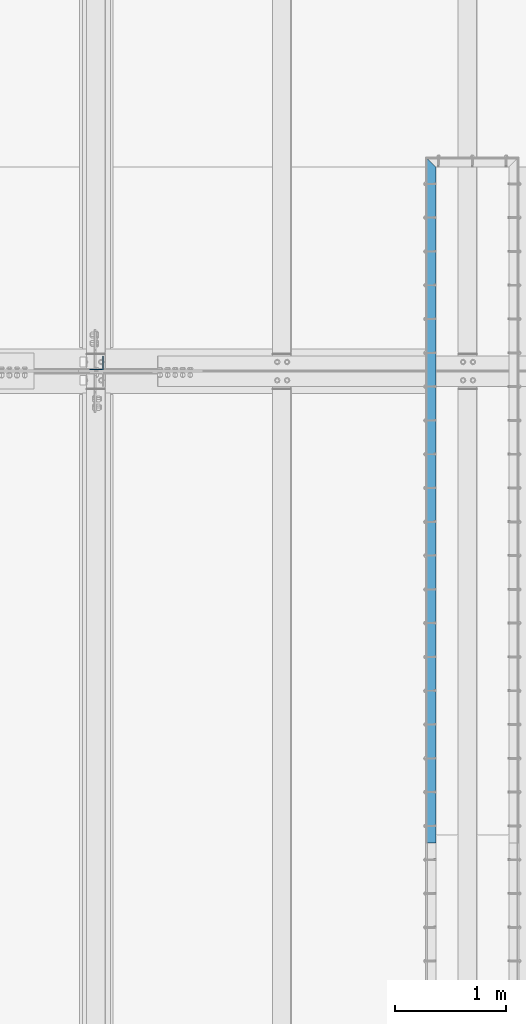
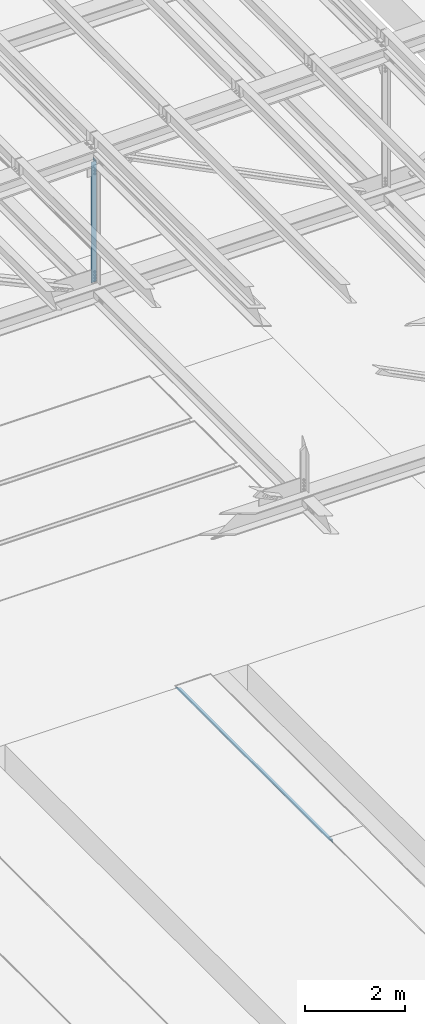
# One storey, part 1845 of 3843: 2 beams, 2 elements without a shape of their own.
"""IFC2X3 building model written with IfcOpenShell, lengths in millimetres."""

from ifc_helpers import new_model, si_unit, frame, origin_with_axes, place, context, subcontext, project, spatial, faceted_brep, material, type_object, element, aggregate, save


model = new_model("IFC2X3")

# Units and contexts
model_context = context("Model", 3, precision=1e-05, world=origin_with_axes())
body_context = subcontext(model_context, "Body", "Model", "MODEL_VIEW")
ifc_project = project(units=[si_unit("LENGTHUNIT", "METRE", prefix="MILLI"), si_unit("AREAUNIT", "SQUARE_METRE"), si_unit("VOLUMEUNIT", "CUBIC_METRE"), si_unit("MASSUNIT", "GRAM", prefix="KILO"), si_unit("TIMEUNIT", "SECOND"), si_unit("PLANEANGLEUNIT", "RADIAN"), si_unit("SOLIDANGLEUNIT", "STERADIAN"), si_unit("THERMODYNAMICTEMPERATUREUNIT", "DEGREE_CELSIUS"), si_unit("LUMINOUSINTENSITYUNIT", "LUMEN")], contexts=[model_context])

# Site, building, storey
site_placement = place(None, origin_with_axes())
site = spatial("IfcSite", under=ifc_project, at=site_placement, CompositionType="ELEMENT")
building_placement = place(site_placement, origin_with_axes())
building = spatial("IfcBuilding", under=site, at=building_placement, Name="Undefined", CompositionType="ELEMENT")
storey_placement = place(building_placement, origin_with_axes())
storey = spatial("IfcBuildingStorey", under=building, at=storey_placement, Name="Undefined", CompositionType="ELEMENT", Elevation=0.0)

# Assembly, beam
assembly_1_placement = place(storey_placement, origin_with_axes())
assembly_1 = element("IfcElementAssembly", 1, at=assembly_1_placement, inside=storey, Name="EMBED_ANGLE", AssemblyPlace="NOTDEFINED", PredefinedType="RIGID_FRAME")
ifc_material_1 = material(Name="STEEL/A36")
beam_type_1 = type_object("IfcBeamType", Name="L3-1/2X3-1/2X5/16", PredefinedType="NOTDEFINED")
beam_1_placement = place(assembly_1_placement, frame((58947.8753603516, 46304.072265625, 30410.15), z_axis=(0.0, 0.0, -1.0), x_axis=(0.0, 1.0, 0.0)))
beam_1 = element("IfcBeam", 2, at=beam_1_placement, type_object=beam_type_1, material=ifc_material_1, Name="EMBED_ANGLE", ObjectType="L3-1/2X3-1/2X5/16", context=body_context, shape_type="Brep", body=[
    faceted_brep([(-3.63797880709171e-12, 44.4499999999971, -44.4500000000007), (-3.63797880709171e-12, 44.4499999999971, 44.4500000000007), (6096.0, 44.4499999999971, 44.4500000000007), (6096.0, 44.4499999999971, -44.4500000000007), (-3.63797880709171e-12, 36.5124999999971, 44.4500000000007), (6103.9375, 36.5124999999971, 44.4500000000007), (-3.63797880709171e-12, 36.5124999999971, -36.5125000000007), (6103.9375, 36.5124999999971, -36.5125000000007), (3.63797880709171e-12, -44.4499999999971, -36.5125000000007), (6184.89999999999, -44.4499999999971, -36.5125000000007), (3.63797880709171e-12, -44.4499999999971, -44.4500000000007), (6184.89999999999, -44.4499999999971, -44.4500000000007)], [[[0, 1, 2, 3]], [[1, 4, 5, 2]], [[4, 6, 7, 5]], [[6, 8, 9, 7]], [[8, 10, 11, 9]], [[10, 0, 3, 11]], [[5, 7, 9, 11, 3, 2]], [[10, 8, 6, 4, 1, 0]]]),
])
aggregate(assembly_1, [beam_1])

assembly_2_placement = place(storey_placement, origin_with_axes())
assembly_2 = element("IfcElementAssembly", 3, at=assembly_2_placement, inside=storey, Name="ANGLE", AssemblyPlace="NOTDEFINED", PredefinedType="RIGID_FRAME")
ifc_material_2 = material(Name="STEEL/A572-50")
beam_type_2 = type_object("IfcBeamType", Name="L5X5X3/8", PredefinedType="NOTDEFINED")
beam_2_placement = place(assembly_2_placement, frame((55930.7999998517, 50631.725, 45713.5153476111), z_axis=(-1.0, 0.0, 0.0), x_axis=(0.0, 0.0, -1.0)))
beam_2 = element("IfcBeam", 4, at=beam_2_placement, type_object=beam_type_2, material=ifc_material_2, Name="ANGLE", ObjectType="L5X5X3/8", context=body_context, shape_type="Brep", body=[
    faceted_brep([(224.174509387543, 63.5, -63.5), (224.174509387543, 63.5, 63.5), (3175.94642335663, 63.5, 63.5), (3175.94642335663, 63.5, -63.5), (224.174509387543, 53.9749999999985, 63.5), (3175.94642335663, 53.9749999999985, 63.5), (224.174509387543, 53.9749999999985, -53.9749999999985), (3175.94642335663, 53.9749999999985, -53.9749999999985), (224.174509387543, -63.5, -53.9749999999985), (3175.94642335663, -63.5, -53.9749999999985), (224.174509387543, -63.5, -63.5), (3175.94642335663, -63.5, -63.5)], [[[0, 1, 2, 3]], [[1, 4, 5, 2]], [[4, 6, 7, 5]], [[6, 8, 9, 7]], [[8, 10, 11, 9]], [[10, 0, 3, 11]], [[5, 7, 9, 11, 3, 2]], [[10, 8, 6, 4, 1, 0]]]),
])
aggregate(assembly_2, [beam_2])

save(model, "model.ifc")
